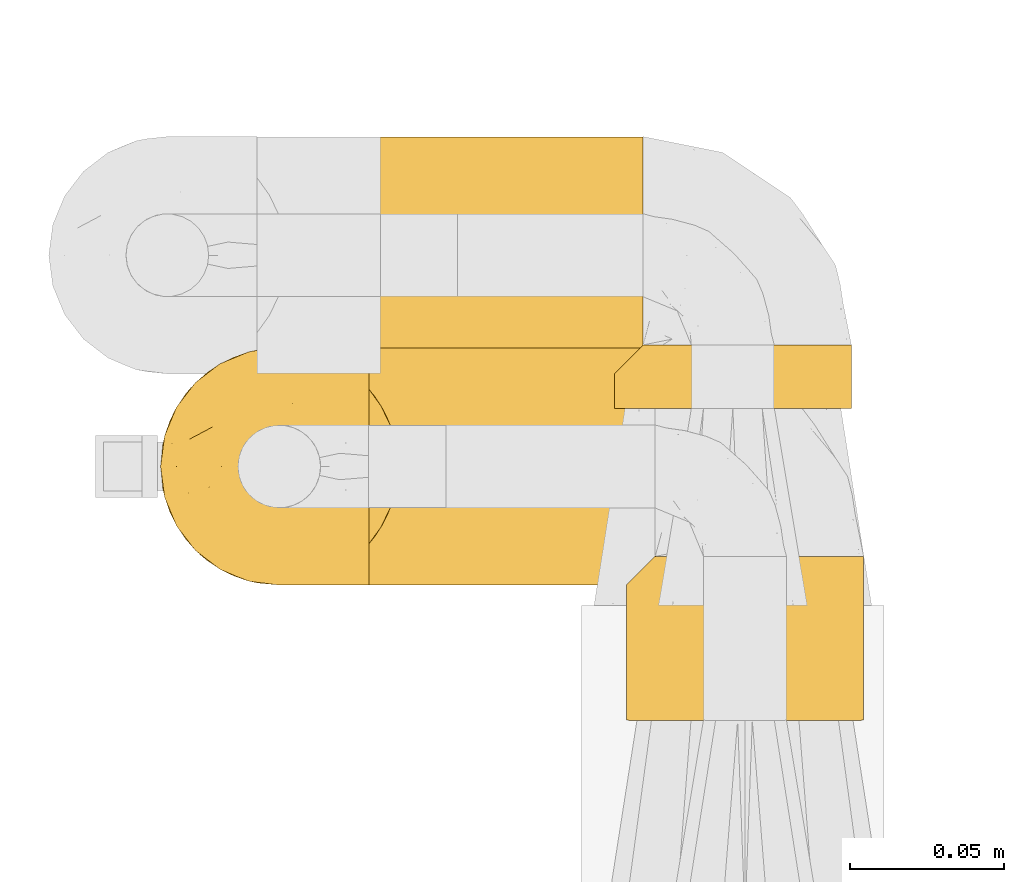
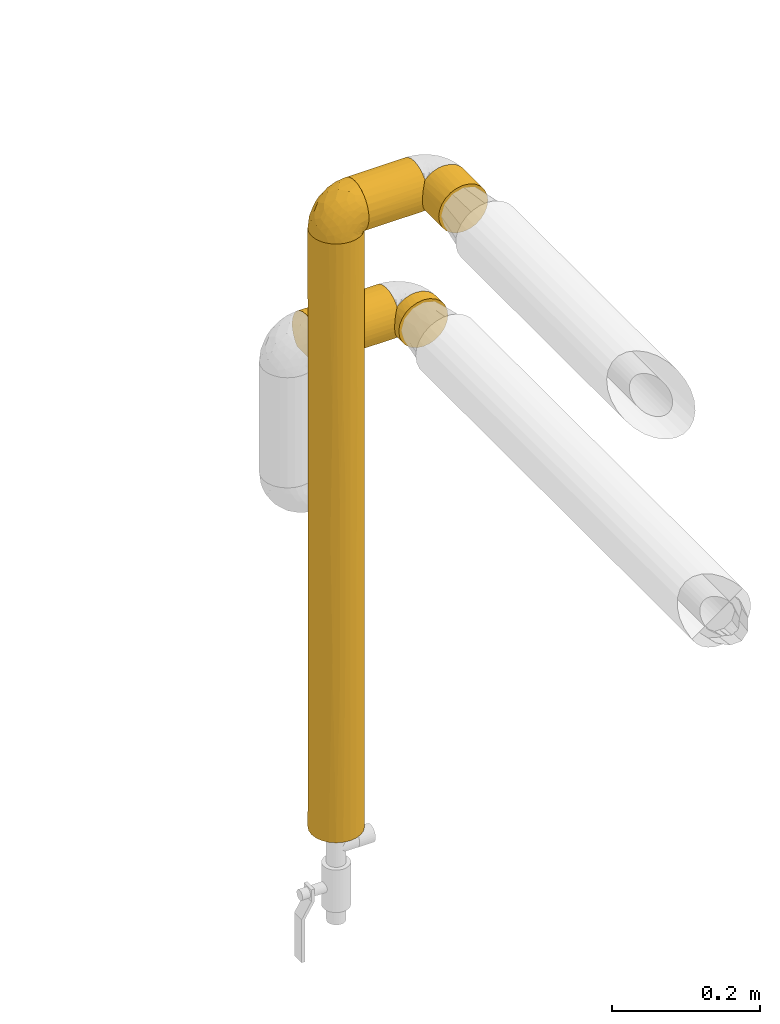
# One storey, part 115 of 827: 6 coverings.
"""IFC2X3 building model written with IfcOpenShell, lengths in millimetres."""

from ifc_helpers import new_model, entity, si_unit, converted_unit, derived_unit, direction, frame, origin, place, context, subcontext, project, spatial, faceted_brep, element, save


model = new_model("IFC2X3")

# Units and contexts
model_context = context("Model", 3, precision=0.01, world=origin(), true_north=direction((6.12303176911189e-17, 1.0)))
body_context = subcontext(model_context, "Body", "Model", "MODEL_VIEW")
ifc_project = project(units=[si_unit("LENGTHUNIT", "METRE", prefix="MILLI"), si_unit("AREAUNIT", "SQUARE_METRE"), si_unit("VOLUMEUNIT", "CUBIC_METRE"), converted_unit("PLANEANGLEUNIT", "DEGREE", entity("IfcRatioMeasure", 0.0174532925199433), si_unit("PLANEANGLEUNIT", "RADIAN"), dimensions=[0, 0, 0, 0, 0, 0, 0]), si_unit("MASSUNIT", "GRAM", prefix="KILO"), derived_unit("MASSDENSITYUNIT", [(si_unit("MASSUNIT", "GRAM", prefix="KILO"), 1), (si_unit("LENGTHUNIT", "METRE"), -3)]), derived_unit("MOMENTOFINERTIAUNIT", [(si_unit("LENGTHUNIT", "METRE"), 4)]), si_unit("TIMEUNIT", "SECOND"), si_unit("FREQUENCYUNIT", "HERTZ"), si_unit("THERMODYNAMICTEMPERATUREUNIT", "DEGREE_CELSIUS"), derived_unit("THERMALTRANSMITTANCEUNIT", [(si_unit("MASSUNIT", "GRAM", prefix="KILO"), 1), (si_unit("THERMODYNAMICTEMPERATUREUNIT", "KELVIN"), -1), (si_unit("TIMEUNIT", "SECOND"), -3)]), derived_unit("VOLUMETRICFLOWRATEUNIT", [(si_unit("LENGTHUNIT", "METRE"), 3), (si_unit("TIMEUNIT", "SECOND"), -1)]), derived_unit("MASSFLOWRATEUNIT", [(si_unit("MASSUNIT", "GRAM", prefix="KILO"), 1), (si_unit("TIMEUNIT", "SECOND"), -1)]), derived_unit("ROTATIONALFREQUENCYUNIT", [(si_unit("TIMEUNIT", "SECOND"), -1)]), si_unit("ELECTRICCURRENTUNIT", "AMPERE"), si_unit("ELECTRICVOLTAGEUNIT", "VOLT"), si_unit("POWERUNIT", "WATT"), si_unit("FORCEUNIT", "NEWTON", prefix="KILO"), si_unit("ILLUMINANCEUNIT", "LUX"), si_unit("LUMINOUSFLUXUNIT", "LUMEN"), si_unit("LUMINOUSINTENSITYUNIT", "CANDELA"), derived_unit("USERDEFINED", [(si_unit("MASSUNIT", "GRAM", prefix="KILO"), -1), (si_unit("LENGTHUNIT", "METRE"), -2), (si_unit("TIMEUNIT", "SECOND"), 3), (si_unit("LUMINOUSFLUXUNIT", "LUMEN"), 1)]), derived_unit("LINEARVELOCITYUNIT", [(si_unit("LENGTHUNIT", "METRE"), 1), (si_unit("TIMEUNIT", "SECOND"), -1)]), si_unit("PRESSUREUNIT", "PASCAL"), derived_unit("USERDEFINED", [(si_unit("LENGTHUNIT", "METRE"), -2), (si_unit("MASSUNIT", "GRAM", prefix="KILO"), 1), (si_unit("TIMEUNIT", "SECOND"), -2)]), derived_unit("LINEARFORCEUNIT", [(si_unit("MASSUNIT", "GRAM", prefix="KILO"), 1), (si_unit("LENGTHUNIT", "METRE"), 1), (si_unit("TIMEUNIT", "SECOND"), -2), (si_unit("LENGTHUNIT", "METRE"), -1)]), derived_unit("PLANARFORCEUNIT", [(si_unit("MASSUNIT", "GRAM", prefix="KILO"), 1), (si_unit("LENGTHUNIT", "METRE"), 1), (si_unit("TIMEUNIT", "SECOND"), -2), (si_unit("LENGTHUNIT", "METRE"), -2)])], contexts=[model_context])

# Site, building, storey
site_placement = place(None, origin())
site = spatial("IfcSite", under=ifc_project, at=site_placement, CompositionType="ELEMENT")
building_placement = place(site_placement, origin())
building = spatial("IfcBuilding", under=site, at=building_placement, CompositionType="ELEMENT")
storey_placement = place(building_placement, frame((0.0, 0.0, 28200.0)))
storey = spatial("IfcBuildingStorey", under=building, at=storey_placement, Name="08", CompositionType="ELEMENT", Elevation=28200.0)

# Coverings
covering_1_placement = place(storey_placement, frame((22708.57, 11906.0, 1258.32)))
element("IfcCovering", 1, at=covering_1_placement, inside=storey, Name=":ADSK_", ObjectType=":ADSK_", PredefinedType="INSULATION", context=body_context, shape_type="Brep", body=[
    faceted_brep([(1.6, 2.48, 31.79), (1.6, 1.6, 40.0), (1.6, 2.9, 49.93), (1.6, 6.74, 59.2), (1.6, 12.84, 67.15), (1.6, 20.8, 73.25), (1.6, 30.06, 77.09), (1.6, 40.0, 78.4), (1.6, 49.93, 77.09), (1.6, 59.2, 73.25), (1.6, 67.15, 67.15), (1.6, 73.25, 59.2), (1.6, 77.09, 49.93), (1.6, 78.4, 40.0), (1.6, 77.51, 31.79), (1.6, 74.9, 23.98), (1.6, 70.68, 16.91), (1.6, 65.05, 10.9), (1.6, 14.94, 10.9), (1.6, 9.31, 16.91), (1.6, 5.09, 23.98), (126.7, 10.9, 14.94), (126.7, 16.91, 9.31), (126.7, 23.98, 5.09), (126.7, 31.79, 2.48), (126.7, 40.0, 1.6), (126.7, 49.93, 2.9), (126.7, 59.2, 6.74), (126.7, 67.15, 12.84), (126.7, 73.25, 20.8), (126.7, 77.09, 30.06), (126.7, 78.4, 40.0), (126.7, 77.09, 49.93), (126.7, 73.25, 59.2), (126.7, 67.15, 67.15), (126.7, 59.2, 73.25), (126.7, 49.93, 77.09), (126.7, 40.0, 78.4), (126.7, 31.79, 77.51), (126.7, 23.98, 74.9), (126.7, 16.91, 70.68), (126.7, 10.9, 65.05), (8.5, 53.36, 4.0), (10.29, 46.78, 2.2), (10.9, 40.0, 1.6), (5.57, 59.51, 6.92), (10.29, 33.21, 2.2), (8.5, 26.63, 4.0), (5.57, 20.48, 6.92), (122.73, 6.92, 20.48), (119.8, 4.0, 26.63), (118.0, 2.2, 33.21), (117.4, 1.6, 40.0), (118.0, 2.2, 46.78), (119.8, 4.0, 53.36), (122.73, 6.92, 59.51)], [[[0, 1, 2, 3, 4, 5, 6, 7, 8, 9, 10, 11, 12, 13, 14, 15, 16, 17, 18, 19, 20]], [[21, 22, 23, 24, 25, 26, 27, 28, 29, 30, 31, 32, 33, 34, 35, 36, 37, 38, 39, 40, 41]], [[31, 30, 14]], [[30, 29, 15]], [[16, 29, 28]], [[14, 13, 31]], [[15, 14, 30]], [[29, 16, 15]], [[28, 17, 16]], [[42, 27, 26]], [[26, 25, 43]], [[44, 43, 25]], [[45, 17, 27]], [[43, 42, 26]], [[45, 27, 42]], [[27, 17, 28]], [[46, 25, 24]], [[47, 24, 23]], [[48, 23, 22]], [[46, 44, 25]], [[48, 47, 23]], [[18, 48, 22]], [[46, 24, 47]], [[22, 21, 18]], [[21, 49, 19]], [[50, 51, 0]], [[49, 50, 20]], [[19, 49, 20]], [[51, 1, 0]], [[0, 20, 50]], [[1, 51, 52]], [[21, 19, 18]], [[53, 54, 2]], [[55, 41, 3]], [[54, 55, 3]], [[52, 53, 1]], [[1, 53, 2]], [[54, 3, 2]], [[41, 4, 3]], [[5, 40, 39]], [[6, 39, 38]], [[7, 38, 37]], [[4, 40, 5]], [[5, 39, 6]], [[38, 7, 6]], [[40, 4, 41]], [[8, 7, 37, 36]], [[9, 8, 36, 35]], [[35, 34, 10, 9]], [[12, 11, 33, 32]], [[13, 12, 32, 31]], [[34, 33, 11, 10]], [[17, 45, 42, 43, 44, 46, 47, 48, 18]], [[52, 51, 50, 49, 21, 41, 55, 54, 53]]]),
])
covering_2_placement = place(storey_placement, frame((22744.82, 11837.51, 1507.66)))
element("IfcCovering", 2, at=covering_2_placement, inside=storey, Name=":ADSK_", ObjectType=":ADSK_", PredefinedType="INSULATION", context=body_context, shape_type="Brep", body=[
    faceted_brep([(1.6, 9.33, 16.89), (1.6, 5.12, 23.94), (1.6, 2.5, 31.72), (1.6, 1.6, 39.89), (1.6, 2.88, 49.83), (1.6, 6.69, 59.11), (1.6, 12.77, 67.07), (1.6, 20.71, 73.2), (1.6, 29.96, 77.06), (1.6, 39.89, 78.39), (1.6, 49.83, 77.11), (1.6, 59.11, 73.3), (1.6, 67.08, 67.22), (1.6, 73.2, 59.29), (1.6, 77.06, 50.03), (1.6, 78.4, 40.1), (1.6, 77.53, 31.87), (1.6, 74.92, 24.03), (1.6, 70.7, 16.93), (1.6, 65.05, 10.89), (1.6, 14.94, 10.9), (94.38, 10.9, 65.05), (94.38, 10.89, 14.95), (94.38, 16.92, 9.3), (94.38, 24.03, 5.07), (94.38, 31.87, 2.47), (94.38, 40.1, 1.6), (94.38, 50.03, 2.93), (94.38, 59.28, 6.79), (94.38, 67.22, 12.92), (94.38, 73.3, 20.89), (94.38, 77.11, 30.16), (94.38, 78.39, 40.1), (94.38, 77.06, 50.03), (94.38, 73.2, 59.29), (94.38, 67.07, 67.22), (94.38, 59.1, 73.3), (94.38, 49.83, 77.11), (94.38, 39.89, 78.39), (94.38, 31.72, 77.49), (94.38, 23.94, 74.88), (94.38, 16.89, 70.67), (8.48, 53.41, 4.01), (10.28, 46.86, 2.21), (10.9, 40.1, 1.6), (5.55, 59.53, 6.94), (10.3, 33.28, 2.19), (8.51, 26.68, 3.98), (5.58, 20.5, 6.91), (90.42, 6.93, 20.46), (87.5, 4.01, 26.59), (85.7, 2.21, 33.13), (85.08, 1.6, 39.89), (85.67, 2.19, 46.71), (87.46, 3.98, 53.31), (90.39, 6.91, 59.49)], [[[0, 1, 2, 3, 4, 5, 6, 7, 8, 9, 10, 11, 12, 13, 14, 15, 16, 17, 18, 19, 20]], [[21, 22, 23, 24, 25, 26, 27, 28, 29, 30, 31, 32, 33, 34, 35, 36, 37, 38, 39, 40, 41]], [[10, 9, 38, 37]], [[11, 10, 37, 36]], [[36, 35, 12, 11]], [[14, 13, 34, 33]], [[15, 14, 33, 32]], [[35, 34, 13, 12]], [[16, 32, 31]], [[17, 31, 30]], [[18, 30, 29]], [[15, 32, 16]], [[16, 31, 17]], [[30, 18, 17]], [[29, 19, 18]], [[42, 28, 27]], [[27, 26, 43]], [[44, 43, 26]], [[45, 19, 28]], [[43, 42, 27]], [[45, 28, 42]], [[28, 19, 29]], [[46, 26, 25]], [[47, 25, 24]], [[48, 24, 23]], [[46, 44, 26]], [[48, 47, 24]], [[20, 48, 23]], [[46, 25, 47]], [[23, 22, 20]], [[22, 49, 0]], [[50, 51, 2]], [[49, 50, 1]], [[0, 49, 1]], [[51, 3, 2]], [[2, 1, 50]], [[3, 51, 52]], [[22, 0, 20]], [[53, 54, 4]], [[55, 21, 5]], [[54, 55, 5]], [[52, 53, 3]], [[3, 53, 4]], [[54, 5, 4]], [[21, 6, 5]], [[7, 41, 40]], [[8, 40, 39]], [[9, 39, 38]], [[6, 41, 7]], [[7, 40, 8]], [[39, 9, 8]], [[41, 6, 21]], [[19, 45, 42, 43, 44, 46, 47, 48, 20]], [[52, 51, 50, 49, 22, 21, 55, 54, 53]]]),
])
covering_3_placement = place(storey_placement, frame((22677.27, 11837.46, 1516.96)))
element("IfcCovering", 3, at=covering_3_placement, inside=storey, Name=":ADSK_", ObjectType=":ADSK_", PredefinedType="INSULATION", context=body_context, shape_type="Brep", body=[
    faceted_brep([(69.15, 74.68, 47.38), (69.15, 70.1, 54.67), (69.15, 64.01, 60.76), (69.15, 56.72, 65.34), (69.15, 48.6, 68.18), (69.15, 40.05, 69.15), (69.15, 31.49, 68.18), (69.15, 23.36, 65.33), (69.15, 16.07, 60.75), (69.15, 9.98, 54.66), (69.15, 5.4, 47.37), (69.15, 2.56, 39.25), (69.15, 1.6, 30.7), (69.15, 2.46, 22.59), (69.15, 5.01, 14.86), (69.15, 9.13, 7.84), (69.15, 14.62, 1.85), (69.15, 16.82, 1.85), (69.15, 18.56, 1.85), (69.15, 20.52, 1.85), (69.15, 22.49, 1.85), (69.15, 24.46, 1.85), (69.15, 26.42, 1.85), (69.15, 28.39, 1.85), (69.15, 30.36, 1.85), (69.15, 32.55, 1.85), (69.15, 34.75, 1.85), (69.15, 36.94, 1.85), (69.15, 39.13, 1.85), (69.15, 41.33, 1.85), (69.15, 43.52, 1.85), (69.15, 45.72, 1.85), (69.15, 47.91, 1.85), (69.15, 50.11, 1.85), (69.15, 52.3, 1.85), (69.15, 54.49, 1.85), (69.15, 56.69, 1.85), (69.15, 58.88, 1.85), (69.15, 61.08, 1.85), (69.15, 63.27, 1.85), (69.15, 65.47, 1.85), (69.15, 70.97, 7.85), (69.15, 75.09, 14.88), (69.15, 77.64, 22.61), (69.15, 78.5, 30.7), (69.15, 77.53, 39.26), (68.89, 14.62, 1.6), (62.89, 9.12, 1.6), (55.87, 5.0, 1.6), (48.14, 2.46, 1.6), (40.05, 1.6, 1.6), (30.09, 2.91, 1.6), (20.82, 6.75, 1.6), (12.86, 12.86, 1.6), (6.75, 20.82, 1.6), (2.91, 30.09, 1.6), (1.6, 40.05, 1.6), (2.91, 50.0, 1.6), (6.75, 59.27, 1.6), (12.86, 67.23, 1.6), (20.82, 73.34, 1.6), (30.09, 77.19, 1.6), (40.05, 78.5, 1.6), (48.14, 77.63, 1.6), (55.87, 75.09, 1.6), (62.89, 70.97, 1.6), (68.89, 65.47, 1.6), (68.89, 63.27, 1.6), (68.89, 62.29, 1.6), (68.89, 60.7, 1.6), (68.89, 59.11, 1.6), (68.89, 57.52, 1.6), (68.89, 55.93, 1.6), (68.89, 54.34, 1.6), (68.89, 52.76, 1.6), (68.89, 51.17, 1.6), (68.89, 49.58, 1.6), (68.89, 47.99, 1.6), (68.89, 46.4, 1.6), (68.89, 44.81, 1.6), (68.89, 43.22, 1.6), (68.89, 41.63, 1.6), (68.89, 40.05, 1.6), (68.89, 38.46, 1.6), (68.89, 36.87, 1.6), (68.89, 35.28, 1.6), (68.89, 33.69, 1.6), (68.89, 32.1, 1.6), (68.89, 30.51, 1.6), (68.89, 28.92, 1.6), (68.89, 27.33, 1.6), (68.89, 25.37, 1.6), (68.89, 23.4, 1.6), (68.89, 21.21, 1.6), (68.89, 19.01, 1.6), (68.89, 16.82, 1.6), (68.97, 42.32, 1.78), (68.96, 44.02, 1.77), (68.97, 47.13, 1.78), (68.97, 48.74, 1.77), (68.98, 23.57, 1.79), (68.97, 25.13, 1.78), (68.96, 61.34, 1.76), (68.96, 22.02, 1.77), (68.96, 29.72, 1.77), (68.96, 56.73, 1.76), (68.96, 55.14, 1.77), (68.96, 37.66, 1.77), (69.0, 64.12, 1.8), (68.96, 28.13, 1.76), (68.96, 26.62, 1.77), (68.97, 31.46, 1.78), (68.96, 16.16, 1.77), (68.96, 39.16, 1.77), (68.96, 50.37, 1.76), (68.97, 17.69, 1.77), (68.97, 19.17, 1.78), (68.97, 62.78, 1.77), (68.96, 58.35, 1.77), (68.96, 45.53, 1.77), (68.97, 59.91, 1.78), (68.97, 65.47, 1.77), (69.02, 65.47, 1.8), (69.08, 65.47, 1.82), (68.97, 14.62, 1.77), (68.94, 14.62, 1.72), (68.92, 14.62, 1.66), (68.96, 20.59, 1.76), (68.96, 32.99, 1.77), (68.95, 34.48, 1.76), (68.96, 51.91, 1.77), (68.92, 65.47, 1.66), (68.94, 65.47, 1.72), (68.98, 53.48, 1.78), (69.08, 14.62, 1.82), (69.02, 14.62, 1.8), (68.96, 40.77, 1.77), (68.97, 35.97, 1.78), (61.33, 7.84, 3.72), (53.1, 3.53, 7.41), (63.33, 8.32, 6.13), (49.27, 1.6, 21.47), (55.53, 2.19, 19.34), (54.6, 1.6, 26.8), (41.99, 1.6, 8.87), (57.07, 4.57, 9.2), (57.95, 3.96, 12.79), (51.56, 2.28, 14.62), (41.58, 1.6, 7.34), (61.7, 7.69, 5.33), (63.33, 3.53, 17.64), (65.0, 8.32, 7.7), (67.02, 7.84, 9.41), (61.87, 1.6, 28.75), (43.94, 1.6, 16.15), (61.21, 4.34, 14.14), (63.4, 1.6, 29.16), (33.11, 29.63, 57.02), (52.82, 27.34, 64.92), (43.3, 40.05, 64.0), (33.73, 2.39, 11.92), (36.52, 2.43, 19.16), (24.87, 9.07, 28.65), (14.17, 16.64, 24.62), (18.43, 9.54, 15.19), (28.67, 4.52, 18.36), (26.0, 4.52, 9.2), (49.25, 7.49, 46.98), (59.72, 7.49, 50.24), (55.1, 12.85, 56.1), (44.72, 2.35, 28.97), (34.15, 22.66, 54.46), (5.25, 32.9, 21.34), (6.75, 25.33, 18.4), (55.54, 40.05, 66.44), (10.47, 16.64, 12.07), (25.49, 19.99, 45.49), (35.53, 16.37, 50.57), (48.22, 3.26, 36.04), (58.71, 3.75, 42.07), (57.42, 19.58, 62.12), (34.84, 7.5, 37.37), (36.87, 4.04, 29.39), (45.01, 13.94, 53.59), (44.4, 19.58, 58.06), (23.96, 28.21, 49.27), (11.2, 24.75, 29.63), (10.56, 31.42, 33.21), (16.81, 26.2, 40.1), (17.38, 33.36, 44.08), (21.38, 40.05, 49.36), (32.34, 40.05, 56.68), (4.3, 40.05, 15.2), (20.65, 16.14, 35.57), (29.66, 12.85, 41.7), (39.6, 10.47, 46.4), (42.55, 6.49, 41.41), (6.74, 40.05, 27.45), (14.06, 40.05, 38.4), (26.84, 75.57, 12.99), (5.28, 47.37, 21.33), (18.52, 52.91, 42.89), (33.13, 50.46, 57.04), (55.1, 67.23, 56.11), (57.43, 60.5, 62.13), (20.72, 70.55, 21.89), (11.46, 63.45, 16.62), (17.69, 62.61, 32.9), (49.26, 72.6, 46.99), (59.73, 72.6, 50.25), (58.71, 76.34, 42.08), (29.72, 59.34, 49.91), (35.35, 77.76, 15.6), (43.94, 78.5, 16.15), (41.99, 78.5, 8.87), (63.4, 78.5, 29.16), (4.93, 53.16, 13.16), (17.46, 70.55, 10.83), (10.94, 48.88, 33.8), (8.92, 54.76, 25.02), (52.83, 52.74, 64.92), (29.34, 71.93, 32.83), (30.26, 75.79, 20.56), (44.4, 60.5, 58.07), (39.06, 77.86, 21.46), (43.06, 77.64, 28.1), (54.6, 78.5, 26.8), (49.27, 78.5, 21.47), (42.69, 67.23, 51.29), (48.2, 76.82, 36.04), (61.87, 78.5, 28.75), (33.44, 77.8, 8.45), (29.67, 67.23, 41.73), (38.5, 73.2, 39.27), (23.35, 67.66, 33.56), (34.97, 75.99, 27.29), (53.1, 76.57, 7.41), (59.68, 73.21, 3.51), (62.19, 71.93, 4.68), (64.11, 71.07, 5.52), (57.97, 75.09, 8.75), (57.95, 76.13, 12.79), (63.33, 76.57, 17.65), (51.77, 77.69, 13.9), (67.02, 72.26, 9.42), (64.98, 71.77, 7.68), (55.53, 77.9, 19.33), (61.22, 75.75, 14.13)], [[[0, 1, 2, 3, 4, 5, 6, 7, 8, 9, 10, 11, 12, 13, 14, 15, 16, 17, 18, 19, 20, 21, 22, 23, 24, 25, 26, 27, 28, 29, 30, 31, 32, 33, 34, 35, 36, 37, 38, 39, 40, 41, 42, 43, 44, 45]], [[46, 47, 48, 49, 50, 51, 52, 53, 54, 55, 56, 57, 58, 59, 60, 61, 62, 63, 64, 65, 66, 67, 68, 69, 70, 71, 72, 73, 74, 75, 76, 77, 78, 79, 80, 81, 82, 83, 84, 85, 86, 87, 88, 89, 90, 91, 92, 93, 94, 95]], [[96, 97, 30]], [[98, 77, 99]], [[100, 101, 21]], [[69, 68, 102]], [[20, 19, 103]], [[24, 23, 104]], [[20, 103, 100]], [[72, 105, 106]], [[84, 83, 107]], [[89, 88, 104]], [[108, 67, 66]], [[109, 110, 90]], [[111, 25, 24]], [[112, 17, 16]], [[82, 113, 83]], [[109, 23, 22]], [[114, 76, 75]], [[105, 36, 106]], [[104, 111, 24]], [[18, 115, 116]], [[97, 96, 80]], [[67, 108, 117]], [[105, 71, 118]], [[31, 97, 119]], [[102, 120, 69]], [[108, 121, 122, 123, 40]], [[112, 95, 115]], [[17, 115, 18]], [[94, 116, 115]], [[117, 68, 67]], [[38, 117, 39]], [[112, 124, 125, 126, 46]], [[17, 112, 115]], [[70, 120, 118]], [[39, 117, 108]], [[120, 38, 37]], [[120, 37, 118]], [[120, 70, 69]], [[116, 94, 127]], [[128, 86, 129]], [[117, 38, 102]], [[74, 130, 75]], [[99, 33, 32]], [[115, 95, 94]], [[39, 108, 40]], [[108, 66, 131, 132, 121]], [[105, 72, 71]], [[118, 37, 36]], [[71, 70, 118]], [[35, 106, 36]], [[36, 105, 118]], [[35, 133, 106]], [[74, 73, 133]], [[106, 133, 73]], [[99, 114, 33]], [[133, 35, 34]], [[73, 72, 106]], [[95, 112, 46]], [[112, 16, 134, 135, 124]], [[130, 114, 75]], [[99, 76, 114]], [[114, 130, 33]], [[34, 33, 130]], [[78, 77, 98]], [[98, 119, 78]], [[130, 133, 34]], [[133, 130, 74]], [[79, 97, 80]], [[98, 99, 32]], [[98, 32, 31]], [[77, 76, 99]], [[97, 79, 119]], [[136, 96, 29]], [[30, 97, 31]], [[136, 29, 28]], [[81, 80, 96]], [[29, 96, 30]], [[31, 119, 98]], [[119, 79, 78]], [[96, 136, 81]], [[82, 81, 136]], [[113, 107, 83]], [[84, 107, 137]], [[107, 27, 137]], [[113, 28, 107]], [[27, 107, 28]], [[85, 84, 137]], [[137, 27, 26]], [[113, 136, 28]], [[136, 113, 82]], [[109, 89, 104]], [[86, 85, 129]], [[89, 109, 90]], [[111, 87, 128]], [[26, 129, 137]], [[88, 111, 104]], [[25, 111, 128]], [[22, 110, 109]], [[23, 109, 104]], [[110, 91, 90]], [[100, 92, 101]], [[110, 22, 101]], [[91, 110, 101]], [[116, 19, 18]], [[111, 88, 87]], [[127, 103, 19]], [[25, 128, 26]], [[86, 128, 87]], [[128, 129, 26]], [[137, 129, 85]], [[120, 102, 38]], [[117, 102, 68]], [[91, 101, 92]], [[21, 101, 22]], [[93, 92, 103]], [[100, 21, 20]], [[100, 103, 92]], [[127, 93, 103]], [[93, 127, 94]], [[116, 127, 19]], [[126, 138, 47]], [[48, 138, 139]], [[140, 125, 124]], [[141, 142, 143]], [[144, 49, 139]], [[145, 140, 146]], [[48, 139, 49]], [[139, 145, 147]], [[49, 144, 148, 50]], [[126, 125, 149]], [[14, 13, 150]], [[151, 146, 140]], [[149, 140, 145]], [[152, 151, 135]], [[152, 14, 150]], [[16, 15, 134]], [[13, 153, 150]], [[124, 151, 140]], [[141, 147, 142]], [[14, 152, 15]], [[15, 152, 134]], [[47, 46, 126]], [[139, 154, 144]], [[138, 48, 47]], [[125, 140, 149]], [[135, 134, 152]], [[146, 155, 142]], [[145, 146, 147]], [[149, 139, 138]], [[147, 141, 154]], [[147, 146, 142]], [[139, 147, 154]], [[139, 149, 145]], [[149, 138, 126]], [[155, 146, 151]], [[150, 143, 142]], [[152, 155, 151]], [[150, 142, 155]], [[13, 12, 156, 153]], [[153, 143, 150]], [[152, 150, 155]], [[151, 124, 135]], [[157, 158, 159]], [[160, 154, 161]], [[162, 163, 164]], [[165, 166, 160]], [[167, 168, 169]], [[141, 170, 161]], [[156, 12, 11]], [[158, 157, 171]], [[172, 55, 173]], [[158, 6, 174]], [[175, 54, 53]], [[52, 166, 164]], [[52, 164, 53]], [[54, 175, 173]], [[166, 52, 51]], [[176, 177, 171]], [[178, 143, 179]], [[156, 11, 179]], [[8, 7, 180]], [[169, 9, 8]], [[179, 143, 153, 156]], [[179, 11, 10]], [[168, 179, 10]], [[181, 162, 182]], [[179, 167, 178]], [[183, 184, 177]], [[183, 169, 184]], [[176, 171, 185]], [[172, 186, 187]], [[158, 7, 6]], [[159, 158, 174]], [[184, 180, 158]], [[54, 173, 55]], [[180, 169, 8]], [[188, 189, 187]], [[9, 168, 10]], [[186, 188, 187]], [[190, 157, 159, 191]], [[55, 172, 192]], [[176, 193, 194]], [[161, 170, 182]], [[162, 164, 165]], [[175, 164, 163]], [[51, 50, 148]], [[167, 195, 196]], [[178, 182, 170]], [[6, 5, 174]], [[158, 180, 7]], [[169, 180, 184]], [[169, 168, 9]], [[179, 168, 167]], [[182, 162, 165]], [[162, 194, 193]], [[161, 165, 160]], [[195, 181, 196]], [[192, 172, 197]], [[192, 56, 55]], [[189, 190, 198]], [[198, 197, 187]], [[172, 187, 197]], [[185, 189, 188]], [[198, 187, 189]], [[186, 172, 173]], [[173, 163, 186]], [[193, 186, 163]], [[176, 185, 188]], [[185, 157, 190]], [[188, 186, 193]], [[177, 176, 194]], [[188, 193, 176]], [[162, 193, 163]], [[195, 177, 194]], [[171, 177, 184]], [[181, 195, 194]], [[183, 167, 169]], [[162, 181, 194]], [[196, 182, 178]], [[158, 171, 184]], [[171, 157, 185]], [[177, 195, 183]], [[167, 183, 195]], [[182, 196, 181]], [[178, 170, 143]], [[178, 167, 196]], [[164, 175, 53]], [[173, 175, 163]], [[160, 51, 148]], [[164, 166, 165]], [[51, 160, 166]], [[160, 148, 144, 154]], [[141, 161, 154]], [[182, 165, 161]], [[190, 189, 185]], [[143, 170, 141]], [[60, 199, 61]], [[197, 200, 192]], [[201, 190, 202]], [[200, 57, 192]], [[203, 204, 2]], [[205, 206, 207]], [[208, 209, 210]], [[211, 207, 201]], [[212, 213, 214]], [[45, 215, 210]], [[216, 206, 58]], [[45, 44, 215]], [[59, 217, 60]], [[60, 217, 199]], [[0, 45, 210]], [[218, 201, 219]], [[202, 159, 220]], [[205, 221, 222]], [[223, 204, 203]], [[1, 203, 2]], [[57, 200, 216]], [[220, 3, 204]], [[220, 174, 4]], [[1, 0, 209]], [[212, 224, 213]], [[225, 226, 227]], [[228, 223, 203]], [[208, 210, 229]], [[210, 226, 229]], [[3, 220, 4]], [[58, 206, 59]], [[209, 203, 1]], [[202, 220, 223]], [[228, 203, 208]], [[202, 211, 201]], [[3, 2, 204]], [[202, 190, 191, 159]], [[210, 215, 230, 226]], [[199, 212, 231]], [[232, 233, 221]], [[233, 208, 229]], [[207, 206, 219]], [[217, 206, 205]], [[227, 224, 225]], [[233, 232, 228]], [[201, 207, 219]], [[234, 232, 221]], [[218, 219, 200]], [[202, 223, 211]], [[174, 220, 159]], [[174, 5, 4]], [[61, 231, 62]], [[220, 204, 223]], [[210, 209, 0]], [[203, 209, 208]], [[225, 233, 229]], [[224, 227, 213]], [[221, 233, 235]], [[57, 56, 192]], [[198, 218, 197]], [[200, 219, 216]], [[201, 198, 190]], [[197, 218, 200]], [[198, 201, 218]], [[206, 216, 219]], [[58, 57, 216]], [[231, 212, 214]], [[222, 212, 199]], [[228, 211, 223]], [[207, 211, 232]], [[62, 231, 214]], [[199, 231, 61]], [[233, 228, 208]], [[211, 228, 232]], [[222, 221, 235]], [[234, 205, 207]], [[206, 217, 59]], [[199, 217, 205]], [[205, 222, 199]], [[224, 222, 235]], [[222, 224, 212]], [[224, 235, 225]], [[233, 225, 235]], [[226, 225, 229]], [[205, 234, 221]], [[207, 232, 234]], [[63, 214, 236]], [[214, 213, 236]], [[214, 63, 62]], [[237, 236, 238]], [[238, 132, 131]], [[236, 237, 64]], [[239, 240, 241]], [[63, 236, 64]], [[131, 66, 65]], [[237, 131, 65]], [[242, 230, 43]], [[237, 65, 64]], [[239, 121, 132]], [[42, 242, 43]], [[241, 240, 243]], [[41, 123, 244]], [[43, 230, 215, 44]], [[244, 122, 245]], [[227, 246, 243]], [[245, 241, 247]], [[121, 239, 245]], [[41, 40, 123]], [[132, 238, 239]], [[244, 42, 41]], [[131, 237, 238]], [[240, 239, 238]], [[245, 239, 241]], [[247, 241, 246]], [[247, 244, 245]], [[238, 236, 240]], [[243, 236, 213]], [[236, 243, 240]], [[246, 241, 243]], [[243, 213, 227]], [[226, 242, 246]], [[227, 226, 246]], [[246, 242, 247]], [[244, 247, 242]], [[242, 226, 230]], [[42, 244, 242]], [[122, 244, 123]], [[122, 121, 245]]]),
])
covering_4_placement = place(storey_placement, frame((22677.32, 11837.51, 530.81)))
element("IfcCovering", 4, at=covering_4_placement, inside=storey, Name=":ADSK_", ObjectType=":ADSK_", PredefinedType="INSULATION", context=body_context, shape_type="Brep", body=[
    faceted_brep([(63.08, 9.31, 987.74), (69.1, 14.94, 987.74), (69.1, 65.05, 987.74), (63.08, 70.68, 987.74), (56.01, 74.9, 987.74), (48.2, 77.51, 987.74), (40.0, 78.4, 987.74), (30.06, 77.09, 987.74), (20.8, 73.25, 987.74), (12.84, 67.15, 987.74), (6.74, 59.2, 987.74), (2.9, 49.93, 987.74), (1.6, 40.0, 987.74), (2.9, 30.06, 987.74), (6.74, 20.8, 987.74), (12.84, 12.84, 987.74), (20.8, 6.74, 987.74), (30.06, 2.9, 987.74), (40.0, 1.6, 987.74), (48.2, 2.48, 987.74), (56.01, 5.09, 987.74), (73.25, 20.8, 0.0), (67.15, 12.84, 0.0), (59.2, 6.74, 0.0), (49.93, 2.9, 0.0), (40.0, 1.6, 0.0), (30.06, 2.9, 0.0), (20.8, 6.74, 0.0), (12.84, 12.84, 0.0), (6.74, 20.8, 0.0), (2.9, 30.06, 0.0), (1.6, 40.0, 0.0), (2.9, 49.93, 0.0), (6.74, 59.2, 0.0), (12.84, 67.15, 0.0), (20.8, 73.25, 0.0), (30.06, 77.09, 0.0), (40.0, 78.4, 0.0), (49.93, 77.09, 0.0), (59.2, 73.25, 0.0), (67.15, 67.15, 0.0), (73.25, 59.2, 0.0), (77.09, 49.93, 0.0), (78.4, 40.0, 0.0), (77.09, 30.06, 0.0), (50.19, 2.97, 384.89), (40.0, 1.6, 277.5), (78.4, 40.0, 272.85), (77.77, 33.09, 194.95), (64.88, 10.75, 469.29), (65.7, 11.47, 670.73), (59.66, 7.01, 554.19), (40.0, 1.6, 771.37), (52.17, 3.58, 722.06), (74.33, 22.81, 615.65), (73.07, 20.48, 983.77), (71.11, 17.49, 747.98), (71.0, 17.34, 490.67), (63.37, 9.53, 273.26), (57.24, 5.69, 347.39), (59.66, 7.01, 787.27), (70.46, 16.62, 224.64), (75.47, 25.3, 294.83), (78.4, 40.0, 545.7), (77.7, 32.72, 409.27), (40.0, 1.6, 216.37), (78.4, 40.0, 762.07), (77.79, 33.21, 979.05), (77.01, 29.79, 671.86), (76.0, 26.63, 980.84), (78.4, 40.0, 978.44), (40.0, 1.6, 555.0), (40.0, 1.6, 432.75), (75.47, 54.69, 294.83), (70.46, 63.37, 224.64), (40.0, 78.4, 555.0), (47.45, 77.67, 416.25), (40.0, 78.4, 277.5), (77.7, 47.27, 409.27), (74.33, 57.18, 615.65), (71.0, 62.65, 490.67), (54.69, 75.47, 281.36), (59.66, 72.98, 554.19), (63.37, 70.46, 252.54), (77.01, 50.2, 671.86), (76.0, 53.36, 980.84), (77.79, 46.78, 979.05), (71.11, 62.5, 747.98), (73.07, 59.51, 983.77), (65.7, 68.52, 670.73), (50.2, 77.02, 663.18), (40.0, 78.4, 771.37), (46.99, 77.75, 199.27), (65.05, 69.1, 457.77), (59.66, 72.98, 787.27), (77.77, 46.9, 194.95), (16.62, 70.46, 225.69), (25.3, 75.47, 310.66), (16.62, 70.46, 762.05), (9.53, 63.37, 699.97), (11.29, 65.5, 505.32), (4.52, 54.69, 559.02), (25.3, 75.47, 677.08), (16.62, 70.46, 493.87), (31.3, 77.4, 443.39), (32.96, 77.74, 663.18), (9.53, 63.37, 310.66), (2.28, 47.21, 324.56), (1.6, 40.0, 432.75), (2.21, 46.85, 560.33), (32.31, 77.62, 220.24), (5.81, 57.48, 744.97), (3.17, 50.87, 758.36), (4.52, 54.69, 256.64), (1.6, 40.0, 216.37), (1.6, 40.0, 277.5), (1.6, 40.0, 771.37), (1.6, 40.0, 555.0), (9.53, 16.62, 225.69), (4.52, 25.3, 310.66), (9.53, 16.62, 762.05), (16.62, 9.53, 699.97), (14.49, 11.29, 505.32), (25.3, 4.52, 559.02), (4.52, 25.3, 677.08), (9.53, 16.62, 493.87), (2.59, 31.3, 443.39), (2.25, 32.96, 663.18), (16.62, 9.53, 310.66), (32.78, 2.28, 324.56), (33.14, 2.21, 560.33), (2.37, 32.31, 220.24), (22.51, 5.81, 744.97), (29.12, 3.17, 758.36), (25.3, 4.52, 256.64)], [[[0, 1, 2, 3, 4, 5, 6, 7, 8, 9, 10, 11, 12, 13, 14, 15, 16, 17, 18, 19, 20]], [[21, 22, 23, 24, 25, 26, 27, 28, 29, 30, 31, 32, 33, 34, 35, 36, 37, 38, 39, 40, 41, 42, 43, 44]], [[45, 46, 24]], [[47, 48, 43]], [[49, 50, 51]], [[19, 52, 53]], [[54, 55, 56]], [[50, 57, 56]], [[45, 51, 53]], [[23, 58, 59]], [[54, 56, 57]], [[53, 51, 60]], [[20, 19, 53]], [[1, 0, 50]], [[60, 0, 20]], [[57, 61, 62]], [[60, 50, 0]], [[63, 64, 47]], [[24, 46, 65, 25]], [[66, 67, 68]], [[59, 24, 23]], [[67, 69, 68]], [[22, 21, 61]], [[1, 56, 55]], [[66, 70, 67]], [[54, 69, 55]], [[68, 54, 64]], [[22, 58, 23]], [[45, 53, 71]], [[62, 21, 44]], [[62, 64, 54]], [[51, 45, 59]], [[58, 22, 61]], [[58, 49, 59]], [[47, 64, 48]], [[53, 60, 20]], [[50, 60, 51]], [[59, 49, 51]], [[50, 56, 1]], [[62, 61, 21]], [[61, 57, 49]], [[68, 64, 63]], [[48, 62, 44]], [[62, 54, 57]], [[69, 54, 68]], [[62, 48, 64]], [[43, 48, 44]], [[61, 49, 58]], [[57, 50, 49]], [[45, 71, 72, 46]], [[68, 63, 66]], [[52, 19, 18]], [[52, 71, 53]], [[59, 45, 24]], [[73, 41, 74]], [[75, 76, 77]], [[78, 63, 47]], [[79, 73, 80]], [[81, 82, 83]], [[84, 85, 86]], [[41, 73, 42]], [[81, 83, 39]], [[85, 84, 79]], [[41, 40, 74]], [[86, 66, 84]], [[87, 2, 88]], [[2, 87, 89]], [[82, 76, 90]], [[91, 90, 75]], [[37, 77, 92]], [[83, 82, 93]], [[4, 94, 90]], [[74, 83, 93]], [[39, 38, 81]], [[94, 4, 3]], [[79, 80, 87]], [[5, 91, 6]], [[39, 83, 40]], [[95, 73, 78]], [[88, 85, 79]], [[94, 89, 82]], [[4, 90, 5]], [[91, 5, 90]], [[82, 81, 76]], [[78, 84, 63]], [[42, 95, 43]], [[82, 89, 93]], [[77, 76, 92]], [[3, 2, 89]], [[90, 94, 82]], [[3, 89, 94]], [[80, 89, 87]], [[83, 74, 40]], [[73, 74, 80]], [[90, 76, 75]], [[92, 81, 38]], [[95, 78, 47]], [[78, 73, 79]], [[89, 80, 93]], [[74, 93, 80]], [[79, 87, 88]], [[79, 84, 78]], [[43, 95, 47]], [[73, 95, 42]], [[81, 92, 76]], [[37, 92, 38]], [[66, 86, 70]], [[66, 63, 84]], [[96, 97, 35]], [[98, 99, 9]], [[100, 101, 99]], [[98, 102, 103]], [[35, 97, 36]], [[75, 77, 104]], [[34, 96, 35]], [[75, 105, 91]], [[98, 9, 8]], [[8, 7, 102]], [[33, 106, 34]], [[100, 98, 103, 96]], [[107, 108, 109]], [[103, 102, 97]], [[97, 110, 36]], [[101, 111, 99]], [[112, 111, 101]], [[10, 9, 99]], [[106, 33, 113]], [[107, 114, 115, 108]], [[116, 12, 11]], [[32, 31, 114]], [[106, 100, 96]], [[7, 91, 105]], [[102, 105, 104]], [[113, 33, 32]], [[109, 112, 101]], [[114, 107, 32]], [[109, 101, 107]], [[36, 110, 37]], [[101, 106, 113]], [[102, 98, 8]], [[106, 96, 34]], [[97, 96, 103]], [[7, 6, 91]], [[77, 110, 104]], [[7, 105, 102]], [[101, 113, 107]], [[32, 107, 113]], [[109, 108, 117, 116]], [[112, 116, 11]], [[116, 112, 109]], [[111, 11, 10]], [[11, 111, 112]], [[10, 99, 111]], [[101, 100, 106]], [[98, 100, 99]], [[104, 110, 97]], [[37, 110, 77]], [[102, 104, 97]], [[75, 104, 105]], [[118, 119, 29]], [[120, 121, 15]], [[122, 123, 121]], [[120, 124, 119, 118, 125]], [[29, 119, 30]], [[126, 117, 108, 115]], [[28, 118, 29]], [[117, 127, 116]], [[120, 15, 14]], [[14, 13, 124]], [[27, 128, 28]], [[122, 120, 125, 118]], [[129, 72, 130]], [[119, 131, 30]], [[123, 132, 121]], [[133, 132, 123]], [[16, 15, 121]], [[128, 27, 134]], [[129, 65, 46, 72]], [[52, 18, 17]], [[26, 25, 65]], [[128, 122, 118]], [[13, 116, 127]], [[124, 127, 126]], [[134, 27, 26]], [[130, 133, 123]], [[65, 129, 26]], [[130, 123, 129]], [[30, 131, 31]], [[123, 128, 134]], [[124, 120, 14]], [[128, 118, 28]], [[13, 12, 116]], [[115, 131, 126]], [[13, 127, 124]], [[123, 134, 129]], [[26, 129, 134]], [[130, 72, 71, 52]], [[133, 52, 17]], [[52, 133, 130]], [[132, 17, 16]], [[17, 132, 133]], [[16, 121, 132]], [[123, 122, 128]], [[120, 122, 121]], [[126, 131, 119]], [[131, 115, 114, 31]], [[124, 126, 119]], [[117, 126, 127]], [[1, 55, 69, 67, 70, 86, 85, 88, 2]]]),
])
covering_5_placement = place(storey_placement, frame((22824.37, 11896.39, 1258.32)))
element("IfcCovering", 5, at=covering_5_placement, inside=storey, Name=":ADSK_", ObjectType=":ADSK_", PredefinedType="INSULATION", context=body_context, shape_type="Brep", body=[
    faceted_brep([(16.91, 20.5, 70.68), (23.98, 20.5, 74.9), (31.79, 20.5, 77.51), (40.0, 20.5, 78.4), (49.93, 20.5, 77.09), (59.2, 20.5, 73.25), (67.15, 20.5, 67.15), (73.25, 20.5, 59.2), (77.09, 20.5, 49.93), (78.4, 20.5, 40.0), (77.09, 20.5, 30.06), (73.25, 20.5, 20.8), (67.15, 20.5, 12.84), (59.2, 20.5, 6.74), (49.93, 20.5, 2.9), (40.0, 20.5, 1.6), (31.79, 20.5, 2.48), (23.98, 20.5, 5.09), (16.91, 20.5, 9.31), (10.9, 20.5, 14.94), (10.9, 20.5, 65.05), (20.8, 0.0, 73.25), (12.84, 0.0, 67.15), (6.74, 0.0, 59.2), (2.9, 0.0, 49.93), (1.6, 0.0, 40.0), (2.9, 0.0, 30.06), (6.74, 0.0, 20.8), (12.84, 0.0, 12.84), (20.8, 0.0, 6.74), (30.06, 0.0, 2.9), (40.0, 0.0, 1.6), (49.93, 0.0, 2.9), (59.2, 0.0, 6.74), (67.15, 0.0, 12.84), (73.25, 0.0, 20.8), (77.09, 0.0, 30.06), (78.4, 0.0, 40.0), (77.09, 0.0, 49.93), (73.25, 0.0, 59.2), (67.15, 0.0, 67.15), (59.2, 0.0, 73.25), (49.93, 0.0, 77.09), (40.0, 0.0, 78.4), (30.06, 0.0, 77.09), (4.0, 13.6, 26.63), (2.2, 11.81, 33.21), (1.6, 11.2, 40.0), (6.92, 16.53, 20.48), (2.2, 11.81, 46.78), (4.0, 13.6, 53.36), (6.92, 16.53, 59.51)], [[[0, 1, 2, 3, 4, 5, 6, 7, 8, 9, 10, 11, 12, 13, 14, 15, 16, 17, 18, 19, 20]], [[21, 22, 23, 24, 25, 26, 27, 28, 29, 30, 31, 32, 33, 34, 35, 36, 37, 38, 39, 40, 41, 42, 43, 44]], [[9, 37, 36, 10]], [[10, 36, 35, 11]], [[11, 35, 34, 12]], [[32, 31, 15, 14]], [[33, 32, 14, 13]], [[12, 34, 33, 13]], [[16, 31, 30]], [[30, 29, 17]], [[28, 18, 29]], [[15, 31, 16]], [[17, 16, 30]], [[18, 17, 29]], [[28, 19, 18]], [[45, 27, 26]], [[26, 25, 46]], [[47, 46, 25]], [[19, 28, 48]], [[46, 45, 26]], [[48, 27, 45]], [[48, 28, 27]], [[49, 47, 25]], [[49, 25, 24]], [[50, 24, 23]], [[50, 49, 24]], [[22, 20, 51]], [[50, 23, 51]], [[51, 23, 22]], [[0, 22, 21]], [[21, 44, 1]], [[43, 2, 44]], [[0, 21, 1]], [[2, 1, 44]], [[3, 2, 43]], [[22, 0, 20]], [[3, 43, 42, 4]], [[4, 42, 41, 5]], [[5, 41, 40, 6]], [[7, 39, 38, 8]], [[8, 38, 37, 9]], [[6, 40, 39, 7]], [[49, 50, 51, 20, 19, 48, 45, 46, 47]]]),
])
covering_6_placement = place(storey_placement, frame((22828.3, 11795.17, 1507.58)))
element("IfcCovering", 6, at=covering_6_placement, inside=storey, Name=":ADSK_", ObjectType=":ADSK_", PredefinedType="INSULATION", context=body_context, shape_type="Brep", body=[
    faceted_brep([(16.97, 53.32, 9.4), (10.97, 53.31, 15.0), (10.82, 53.17, 65.11), (16.84, 53.16, 70.77), (23.93, 53.14, 75.02), (31.77, 53.14, 77.65), (40.0, 53.13, 78.54), (49.93, 53.14, 77.23), (59.2, 53.15, 73.39), (67.15, 53.16, 67.29), (73.25, 53.19, 59.34), (77.09, 53.21, 50.08), (78.4, 53.24, 40.14), (77.09, 53.27, 30.2), (73.25, 53.29, 20.94), (67.15, 53.31, 12.99), (59.2, 53.33, 6.88), (49.93, 53.34, 3.05), (40.0, 53.34, 1.74), (31.82, 53.34, 2.62), (24.03, 53.33, 5.21), (2.9, 0.13, 30.06), (6.74, 0.16, 20.8), (12.84, 0.18, 12.84), (20.8, 0.19, 6.74), (30.06, 0.2, 2.9), (40.0, 0.21, 1.6), (49.93, 0.2, 2.9), (59.2, 0.19, 6.74), (67.15, 0.18, 12.84), (73.25, 0.16, 20.8), (77.09, 0.13, 30.06), (78.4, 0.1, 40.0), (77.09, 0.08, 49.93), (73.25, 0.05, 59.2), (67.15, 0.03, 67.15), (59.2, 0.01, 73.25), (49.93, 0.0, 77.09), (40.0, 0.0, 78.39), (30.06, 0.0, 77.09), (20.8, 0.01, 73.25), (12.84, 0.03, 67.15), (6.74, 0.05, 59.2), (2.9, 0.08, 49.93), (1.6, 0.1, 40.0), (4.01, 46.36, 26.71), (2.2, 44.55, 33.3), (1.6, 43.94, 40.11), (6.97, 49.31, 20.54), (2.2, 44.54, 46.88), (3.98, 46.32, 53.43), (6.88, 49.23, 59.57)], [[[0, 1, 2, 3, 4, 5, 6, 7, 8, 9, 10, 11, 12, 13, 14, 15, 16, 17, 18, 19, 20]], [[21, 22, 23, 24, 25, 26, 27, 28, 29, 30, 31, 32, 33, 34, 35, 36, 37, 38, 39, 40, 41, 42, 43, 44]], [[12, 32, 31, 13]], [[13, 31, 30, 14]], [[29, 15, 14, 30]], [[17, 16, 28, 27]], [[18, 17, 27, 26]], [[29, 28, 16, 15]], [[26, 25, 19]], [[25, 24, 20]], [[0, 24, 23]], [[19, 18, 26]], [[20, 19, 25]], [[24, 0, 20]], [[23, 1, 0]], [[45, 22, 21]], [[21, 44, 46]], [[47, 46, 44]], [[48, 1, 22]], [[46, 45, 21]], [[48, 22, 45]], [[22, 1, 23]], [[49, 47, 44]], [[49, 44, 43]], [[50, 43, 42]], [[50, 49, 43]], [[2, 51, 42]], [[50, 42, 51]], [[42, 41, 2]], [[3, 41, 40]], [[4, 40, 39]], [[5, 39, 38]], [[3, 40, 4]], [[4, 39, 5]], [[38, 6, 5]], [[41, 3, 2]], [[7, 6, 38, 37]], [[8, 7, 37, 36]], [[36, 35, 9, 8]], [[11, 10, 34, 33]], [[12, 11, 33, 32]], [[35, 34, 10, 9]], [[46, 47, 49, 50, 51, 2, 1, 48, 45]]]),
])

save(model, "model.ifc")
